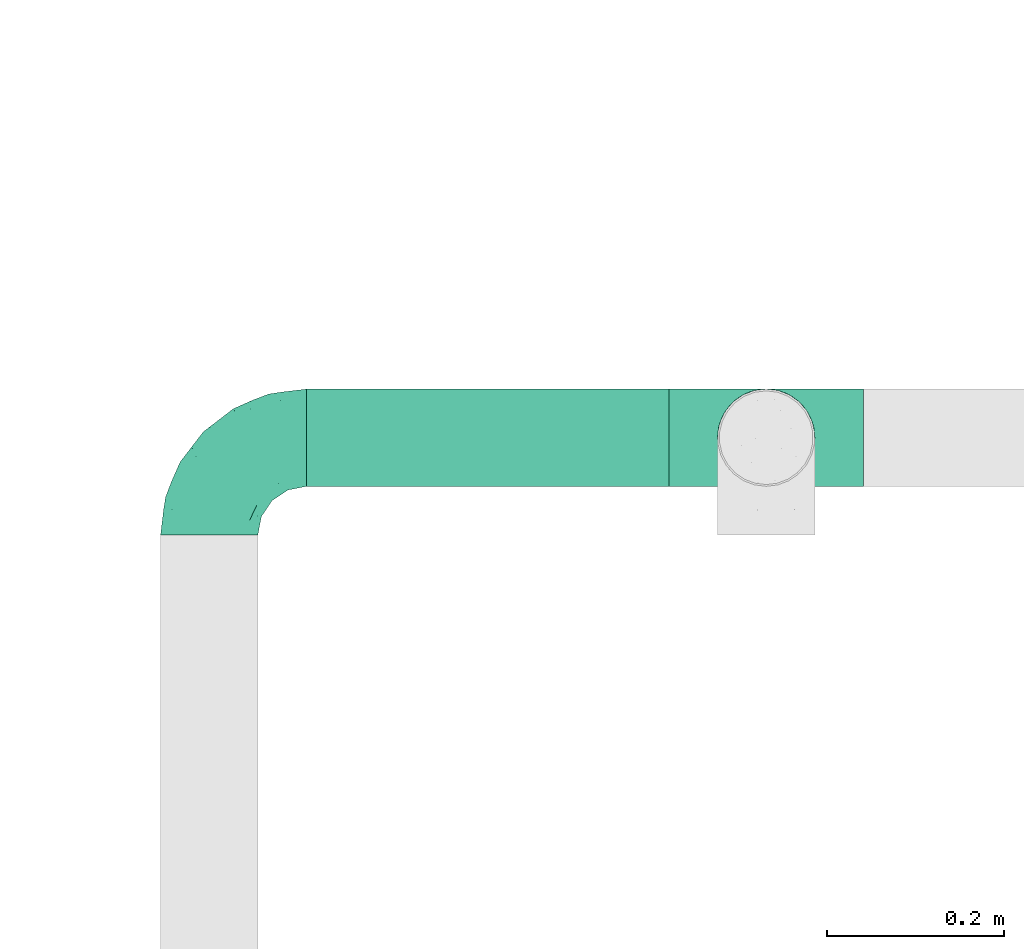
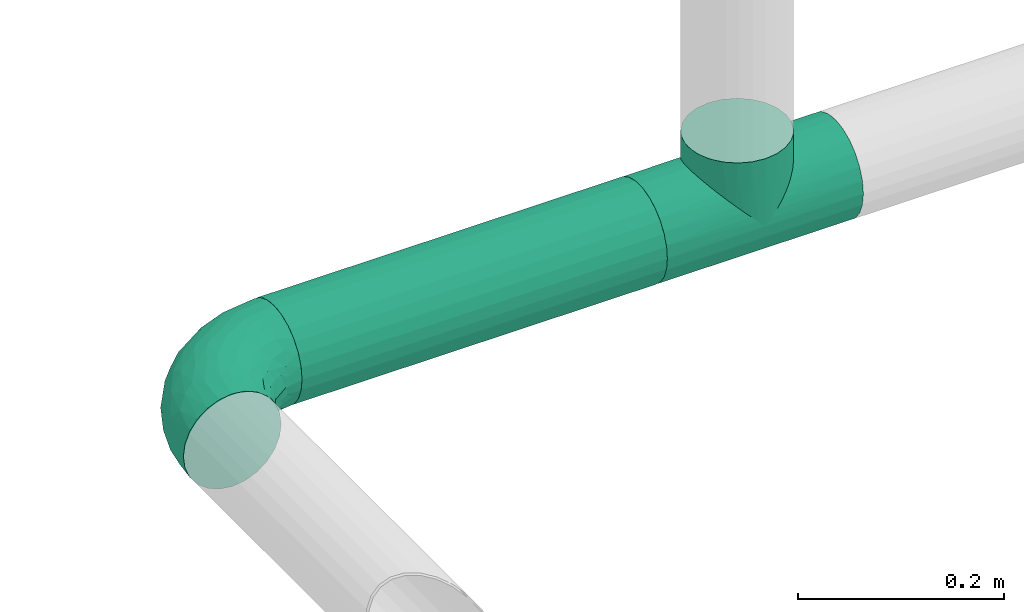
# One storey, part 73 of 103: 2 flow fittings, 1 flow segment.
"""IFC2X3 building model written with IfcOpenShell, lengths in millimetres."""

from ifc_helpers import new_model, entity, si_unit, converted_unit, derived_unit, direction, frame, origin_with_axes, origin_2d_with_axis, place, context, subcontext, project, spatial, hollow_circle, extrude, open_shell, surface_model, source, transform, mapped, material, layer, layer_set, layer_usage, type_object, element, save


model = new_model("IFC2X3")

# Units and contexts
model_context = context("Model", 3, precision=1e-05, world=origin_with_axes(), true_north=direction((0.0, 1.0)))
body_context = subcontext(model_context, "Body", "Model", "MODEL_VIEW")
ifc_project = project(units=[si_unit("AREAUNIT", "SQUARE_METRE"), si_unit("VOLUMEUNIT", "CUBIC_METRE", prefix="DECI"), si_unit("TIMEUNIT", "SECOND"), si_unit("THERMODYNAMICTEMPERATUREUNIT", "DEGREE_CELSIUS"), si_unit("PRESSUREUNIT", "PASCAL"), si_unit("MASSUNIT", "GRAM", prefix="KILO"), si_unit("LENGTHUNIT", "METRE", prefix="MILLI"), si_unit("POWERUNIT", "WATT"), si_unit("ELECTRICCURRENTUNIT", "AMPERE"), si_unit("ELECTRICVOLTAGEUNIT", "VOLT"), derived_unit("VOLUMETRICFLOWRATEUNIT", [(si_unit("VOLUMEUNIT", "CUBIC_METRE", prefix="DECI"), 1), (si_unit("TIMEUNIT", "SECOND"), -1)]), derived_unit("LINEARVELOCITYUNIT", [(si_unit("LENGTHUNIT", "METRE"), 1), (si_unit("TIMEUNIT", "SECOND"), -1)]), derived_unit("MASSDENSITYUNIT", [(si_unit("MASSUNIT", "GRAM", prefix="KILO"), 1), (si_unit("VOLUMEUNIT", "CUBIC_METRE"), -1)]), converted_unit("PLANEANGLEUNIT", "DEGREE", entity("IfcRatioMeasure", 0.01745), si_unit("PLANEANGLEUNIT", "RADIAN"), dimensions=[0, 0, 0, 0, 0, 0, 0])], contexts=[model_context])

# Site, building, storey
site_placement = place(None, origin_with_axes())
site = spatial("IfcSite", under=ifc_project, at=site_placement, CompositionType="ELEMENT")
building_placement = place(site_placement, origin_with_axes())
building = spatial("IfcBuilding", under=site, at=building_placement, Name="mc-building", CompositionType="ELEMENT")
storey_placement = place(building_placement, frame((0.0, 0.0, 5900.0), z_axis=(0.0, 0.0, 1.0), x_axis=(1.0, 0.0, 0.0)))
storey = spatial("IfcBuildingStorey", under=building, at=storey_placement, Name="3. Korrus", CompositionType="ELEMENT", Elevation=5900.0)

# Flow segment
ifc_material = material(Name="FZ1")
ifc_layer = layer(ifc_material, 0.0)
ifc_layer_set = layer_set([ifc_layer], Name="FZ1")
ifc_layer_usage = layer_usage(ifc_layer_set, "AXIS1", "POSITIVE", 0.0)
duct_segment_type = type_object("IfcDuctSegmentType", PredefinedType="RIGIDSEGMENT")
shared_shape_1 = source(origin_with_axes(), body_context, "Body", "SweptSolid", [
    extrude(hollow_circle(Radius=55.0, WallThickness=2.0, at=origin_2d_with_axis()), frame((0.0, 0.0, 0.0), z_axis=(1.0, 0.0, 0.0), x_axis=(0.0, 1.0, 0.0)), (0.0, 0.0, 1.0), 410.1),
])
flow_segment_placement = place(storey_placement, frame((18806.22014, 9477.62755, 2345.0), z_axis=(0.0, 0.0, 1.0), x_axis=(1.0, 0.0, 0.0)))
element("IfcFlowSegment", 1, at=flow_segment_placement, inside=storey, type_object=duct_segment_type, material=ifc_layer_usage, context=body_context, shape_type="MappedRepresentation", body=[
    mapped(shared_shape_1, transform((0.0, 0.0, 0.0), scale=1.0)),
])

# Flow fittings
duct_fitting_type_1 = type_object("IfcDuctFittingType", Name="BU", PredefinedType="BEND")
shared_shape_2 = source(origin_with_axes(), body_context, "Body", "SurfaceModel", [
    surface_model("IfcShellBasedSurfaceModel", [(-110.0, -38.89087, -38.89087), (-110.0, -55.0, 0.0), (-110.0, -27.5, -47.63139), (-110.0, -53.12592, -14.23505), (-110.0, -47.63139, -27.5), (-110.0, 47.63139, -27.5), (-110.0, 53.12592, 14.23505), (-110.0, 53.12592, -14.23505), (-110.0, -14.23505, -53.12592), (-110.0, 0.0, -55.0), (-110.0, 38.89087, -38.89087), (-110.0, 27.5, -47.63139), (-110.0, 14.23505, -53.12592), (-110.0, 55.0, 0.0), (-110.0, -53.12592, 14.23505), (-110.0, -47.63139, 27.5), (-110.0, -38.89087, 38.89087), (-110.0, 0.0, 55.0), (-110.0, -27.5, 47.63139), (-110.0, -14.23505, 53.12592), (-110.0, 38.89087, 38.89087), (-110.0, 47.63139, 27.5), (-110.0, 27.5, 47.63139), (-110.0, 14.23505, 53.12592), (0.0, -110.0, -55.0), (14.23505, -110.0, -53.12592), (-14.23505, -110.0, -53.12592), (-53.12592, -110.0, 14.23505), (-27.5, -110.0, -47.63139), (-47.63139, -110.0, -27.5), (-38.89087, -110.0, -38.89087), (55.0, -110.0, 0.0), (53.12592, -110.0, 14.23505), (38.89087, -110.0, -38.89087), (27.5, -110.0, -47.63139), (53.12592, -110.0, -14.23505), (47.63139, -110.0, -27.5), (-53.12592, -110.0, -14.23505), (-47.63139, -110.0, 27.5), (-38.89087, -110.0, 38.89087), (14.23505, -110.0, 53.12592), (-27.5, -110.0, 47.63139), (-14.23505, -110.0, 53.12592), (47.63139, -110.0, 27.5), (38.89087, -110.0, 38.89087), (27.5, -110.0, 47.63139), (0.0, -110.0, 55.0), (-55.0, -110.0, 0.0), (-60.44912, -32.56953, 51.94617), (-76.6405, -38.18013, 45.55988), (-64.21732, -48.68956, 43.63444), (-90.15553, -11.94394, 54.09138), (-76.00813, -5.38378, 55.0), (-70.18771, -18.55163, 54.03432), (-78.5998, -26.77405, 50.81338), (-93.27622, -45.77614, 33.48188), (-75.55424, -54.2118, 32.41257), (-96.12334, -22.13664, 50.81337), (-32.04182, -59.64019, 52.24446), (-18.36258, -70.48427, 54.04484), (-21.00813, -45.34362, 55.0), (-63.60674, -66.07878, 29.97482), (-74.66383, -63.08407, 19.92123), (-63.88653, -74.77858, 17.99134), (-93.11138, -56.59448, 10.50359), (-99.597, -52.72185, 18.52927), (-98.21577, -57.34403, 0.0), (-53.42855, -92.60092, 21.04759), (-88.54852, -54.8376, 21.04759), (-5.38378, -76.00813, 55.0), (-11.86161, -90.23965, 54.10313), (-56.64619, -93.12774, 10.22088), (-57.34403, -98.21577, 0.0), (-44.60838, -44.60838, 52.13415), (-45.34362, -21.00813, 55.0), (-92.68484, -35.46673, 43.63443), (-22.25266, -95.40765, 50.81337), (-27.23711, -77.39884, 50.81337), (-43.70931, -69.58671, 44.47149), (-35.97783, -90.61597, 43.63443), (-58.67786, -84.31125, 16.04456), (-57.2828, -79.3123, 24.9774), (-82.93277, -60.36161, 12.91784), (-49.88337, -54.51816, 47.224), (-74.57753, -66.83759, 9.55742), (-45.35812, -94.97281, 33.48188), (-59.18663, -88.95241, 0.0), (-51.517, -78.6292, 33.48188), (-65.14788, -80.03077, 0.0), (-56.45322, -62.06476, 39.63545), (-88.95241, -59.18663, 0.0), (-80.03077, -65.14788, 0.0), (-71.10913, -71.10913, 0.0), (-94.9309, -45.36788, -33.48188), (-93.11358, -56.60141, -10.46614), (-99.64997, -52.79499, -18.30015), (-79.99933, -46.56772, -37.92748), (-90.20425, -36.08686, -43.63443), (-45.34362, -21.00813, -55.0), (-72.75364, -19.68651, -53.60527), (-76.00813, -5.38378, -55.0), (-21.00813, -45.34362, -55.0), (-5.38378, -76.00813, -55.0), (-21.91957, -65.12078, -53.85897), (-35.41876, -92.89265, -43.63443), (-91.10309, -11.02766, -54.21832), (-45.77614, -93.27622, -33.48188), (-90.50474, -23.21022, -50.81337), (-70.92854, -33.31794, -49.51754), (-78.52933, -63.35627, -11.73997), (-24.91508, -84.05606, -50.81337), (-88.78941, -54.74452, -21.04759), (-63.49062, -67.59111, -28.46929), (-73.36422, -62.46673, -22.94182), (-69.59921, -57.34866, -33.48187), (-56.59448, -93.11138, -10.50359), (-54.10679, -75.85581, -32.31867), (-54.8376, -88.54852, -21.04759), (-57.75956, -31.09612, -52.80882), (-52.72185, -99.597, -18.52927), (-12.62913, -89.46304, -53.99097), (-34.46825, -66.46123, -50.04329), (-43.9837, -43.9837, -52.42279), (-65.78527, -72.58348, -17.68796), (-57.47001, -51.99467, -44.91465), (-70.34468, -43.65295, -44.21951), (-60.72547, -82.29174, -12.88567), (-42.34915, -74.24548, -43.63444), (-57.25194, -63.5016, -38.08211), (-80.95344, -53.56991, -29.32027), (-52.32891, -4.55257, -54.0482), (14.95561, -36.05775, -42.26543), (14.88266, -20.92917, -33.7947), (32.52942, -47.13398, -30.48571), (19.3559, -65.35825, -48.00507), (30.24048, -70.09027, -41.7461), (-28.49299, 30.5778, -16.4009), (-47.13398, 32.52942, -30.48571), (-70.35075, 46.44478, -19.5952), (-22.4954, -22.4954, -53.25347), (-4.55257, -52.32891, -54.0482), (-75.47368, 11.22546, -52.60718), (-81.32209, 51.5606, -9.98467), (-70.09027, 30.24048, -41.7461), (-80.81763, 41.84862, -32.14655), (-9.15831, 10.852, -27.8997), (-36.05774, 14.95561, -42.26543), (-65.35825, 19.3559, -48.00507), (3.94376, -43.9333, -50.53315), (11.22546, -75.47368, -52.60718), (-43.9333, 3.94376, -50.53315), (-13.39742, -13.39743, -48.13058), (50.20582, -74.51695, -9.9731), (41.8609, -47.82256, -9.92641), (49.37776, -67.29486, 0.0), (18.93131, -11.7156, -17.56239), (-1.23348, 12.25375, -12.18106), (-27.5, 32.89419, 0.0), (41.84862, -80.81763, -32.14655), (46.44478, -70.35075, -19.5952), (35.70604, -41.31408, -20.38235), (6.67262, 6.67262, 0.0), (32.89419, -27.5, 0.0), (-50.36265, 42.95545, -9.51562), (-67.29486, 49.37776, 0.0), (-5.47251, -5.47251, -39.92906), (-70.35075, 46.44478, 19.5952), (-74.51695, 50.20582, 9.9731), (-47.13398, 32.52942, 30.48571), (-41.31407, 35.70604, 20.38235), (-80.81763, 41.84862, 32.14655), (11.22546, -75.47368, 52.60718), (-4.55257, -52.32891, 54.0482), (-36.05774, 14.95561, 42.26543), (-65.35825, 19.3559, 48.00507), (-43.9333, 3.94376, 50.53315), (-70.09027, 30.24048, 41.7461), (-11.7156, 18.93131, 17.56239), (12.25375, -1.23348, 12.18106), (30.5778, -28.49299, 16.4009), (42.95545, -50.36265, 9.51562), (51.5606, -81.32209, 9.98467), (-52.32891, -4.55257, 54.0482), (-75.47368, 11.22546, 52.60718), (-13.39742, -13.39743, 48.13058), (-22.4954, -22.4954, 53.25347), (3.94376, -43.9333, 50.53315), (-20.92916, 14.88266, 33.79469), (10.852, -9.15831, 27.8997), (-47.82256, 41.8609, 9.92641), (32.52942, -47.13398, 30.48571), (46.44478, -70.35075, 19.5952), (41.84862, -80.81763, 32.14655), (14.95561, -36.05775, 42.26543), (19.3559, -65.35825, 48.00507), (30.24048, -70.09027, 41.7461), (-5.47251, -5.47251, 39.92906)], [open_shell([[[0, 1, 2]], [[3, 1, 4]], [[5, 6, 7]], [[8, 1, 9]], [[2, 1, 8]], [[4, 1, 0]], [[10, 9, 6]], [[9, 10, 11]], [[11, 12, 9]], [[6, 5, 10]], [[7, 6, 13]], [[14, 15, 9]], [[9, 15, 16]], [[17, 16, 18]], [[9, 16, 17]], [[19, 17, 18]], [[9, 20, 21]], [[6, 9, 21]], [[9, 22, 20]], [[23, 22, 9]], [[17, 23, 9]], [[9, 1, 14]], [[24, 25, 26]], [[26, 27, 28]], [[29, 30, 27]], [[28, 27, 30]], [[26, 31, 32]], [[33, 31, 34]], [[25, 34, 31]], [[35, 31, 36]], [[33, 36, 31]], [[31, 26, 25]], [[29, 27, 37]], [[38, 27, 26]], [[39, 38, 26]], [[40, 41, 26]], [[41, 39, 26]], [[40, 42, 41]], [[43, 44, 26]], [[43, 26, 32]], [[44, 45, 26]], [[26, 45, 40]], [[40, 46, 42]], [[47, 37, 27]], [[48, 49, 50]], [[51, 52, 17]], [[48, 53, 54]], [[49, 55, 56]], [[16, 15, 55]], [[18, 57, 19]], [[58, 59, 60]], [[61, 62, 63]], [[64, 65, 14]], [[53, 51, 54]], [[66, 64, 14]], [[27, 38, 67]], [[65, 68, 55]], [[68, 65, 64]], [[69, 59, 70]], [[71, 72, 27]], [[73, 60, 74]], [[55, 49, 75]], [[42, 70, 76]], [[51, 57, 54]], [[77, 78, 79]], [[42, 76, 41]], [[46, 70, 42]], [[55, 68, 56]], [[75, 18, 16]], [[77, 79, 76]], [[80, 67, 81]], [[68, 82, 62]], [[83, 78, 58]], [[82, 84, 62]], [[39, 79, 85]], [[71, 67, 80]], [[72, 71, 86]], [[67, 85, 87]], [[88, 80, 63]], [[39, 41, 79]], [[87, 79, 78]], [[55, 75, 16]], [[50, 89, 83]], [[38, 39, 85]], [[56, 68, 62]], [[61, 87, 89]], [[48, 50, 83]], [[18, 75, 57]], [[54, 75, 49]], [[38, 85, 67]], [[85, 79, 87]], [[56, 62, 61]], [[50, 56, 89]], [[87, 61, 81]], [[90, 64, 66]], [[14, 1, 66]], [[91, 92, 84]], [[82, 90, 91]], [[90, 82, 64]], [[62, 84, 63]], [[84, 82, 91]], [[64, 82, 68]], [[65, 15, 14]], [[15, 65, 55]], [[72, 47, 27]], [[86, 71, 80]], [[67, 71, 27]], [[88, 63, 92]], [[63, 80, 81]], [[63, 81, 61]], [[87, 81, 67]], [[41, 76, 79]], [[70, 59, 77]], [[76, 70, 77]], [[69, 70, 46]], [[77, 59, 58]], [[59, 69, 60]], [[77, 58, 78]], [[73, 58, 60]], [[19, 57, 51]], [[54, 57, 75]], [[19, 51, 17]], [[53, 52, 51]], [[53, 74, 52]], [[73, 74, 48]], [[53, 48, 74]], [[83, 73, 48]], [[73, 83, 58]], [[78, 83, 89]], [[78, 89, 87]], [[61, 89, 56]], [[54, 49, 48]], [[50, 49, 56]], [[88, 86, 80]], [[63, 84, 92]], [[93, 4, 0]], [[66, 94, 90]], [[95, 94, 3]], [[96, 93, 97]], [[98, 99, 100]], [[0, 2, 97]], [[101, 102, 103]], [[104, 28, 30]], [[9, 105, 8]], [[30, 106, 104]], [[107, 105, 99]], [[97, 107, 108]], [[94, 109, 90]], [[2, 8, 107]], [[94, 66, 3]], [[110, 26, 28]], [[94, 111, 109]], [[112, 113, 114]], [[72, 115, 37]], [[116, 106, 117]], [[98, 118, 99]], [[119, 115, 117]], [[115, 119, 37]], [[110, 120, 26]], [[103, 110, 121]], [[117, 106, 119]], [[120, 110, 103]], [[98, 101, 122]], [[117, 123, 116]], [[108, 124, 125]], [[126, 117, 115]], [[30, 29, 106]], [[120, 102, 24]], [[110, 104, 127]], [[97, 125, 96]], [[118, 122, 124]], [[124, 127, 128]], [[93, 0, 97]], [[86, 126, 115]], [[127, 106, 116]], [[129, 113, 111]], [[4, 93, 95]], [[114, 129, 96]], [[28, 104, 110]], [[127, 104, 106]], [[2, 107, 97]], [[108, 107, 99]], [[118, 108, 99]], [[100, 99, 105]], [[128, 112, 114]], [[127, 124, 121]], [[66, 1, 3]], [[91, 90, 109]], [[95, 111, 94]], [[109, 123, 92]], [[114, 113, 129]], [[111, 95, 93]], [[95, 3, 4]], [[86, 115, 72]], [[37, 47, 72]], [[88, 92, 123]], [[123, 117, 126]], [[126, 88, 123]], [[88, 126, 86]], [[119, 29, 37]], [[29, 119, 106]], [[111, 93, 129]], [[124, 114, 125]], [[100, 105, 9]], [[8, 105, 107]], [[108, 118, 124]], [[122, 118, 98]], [[96, 129, 93]], [[109, 111, 113]], [[113, 123, 109]], [[116, 123, 112]], [[113, 112, 123]], [[116, 112, 128]], [[116, 128, 127]], [[124, 128, 114]], [[103, 122, 101]], [[127, 121, 110]], [[121, 122, 103]], [[122, 121, 124]], [[26, 120, 24]], [[102, 120, 103]], [[108, 125, 97]], [[109, 92, 91]], [[96, 125, 114]], [[100, 130, 98]], [[131, 132, 133]], [[134, 135, 34]], [[136, 137, 138]], [[101, 139, 140]], [[9, 141, 100]], [[138, 7, 142]], [[137, 143, 144]], [[142, 7, 13]], [[145, 146, 137]], [[146, 147, 143]], [[5, 138, 144]], [[7, 138, 5]], [[5, 144, 10]], [[140, 148, 149]], [[143, 11, 10]], [[147, 12, 11]], [[100, 141, 130]], [[98, 139, 101]], [[148, 134, 149]], [[139, 150, 151]], [[152, 153, 154]], [[150, 139, 130]], [[25, 24, 149]], [[141, 12, 147]], [[132, 145, 155]], [[156, 136, 157]], [[158, 33, 135]], [[148, 139, 151]], [[36, 33, 158]], [[34, 135, 33]], [[159, 160, 153]], [[160, 159, 133]], [[137, 146, 143]], [[152, 154, 31]], [[137, 136, 145]], [[161, 162, 155]], [[133, 159, 158]], [[134, 148, 131]], [[163, 164, 157]], [[163, 142, 164]], [[102, 101, 140]], [[162, 154, 153]], [[159, 35, 36]], [[155, 156, 161]], [[131, 165, 132]], [[155, 145, 156]], [[98, 130, 139]], [[150, 130, 141]], [[147, 150, 141]], [[9, 12, 141]], [[149, 24, 102]], [[148, 140, 139]], [[140, 149, 102]], [[34, 25, 134]], [[146, 151, 150]], [[143, 147, 11]], [[147, 146, 150]], [[145, 165, 146]], [[25, 149, 134]], [[135, 134, 131]], [[135, 131, 133]], [[151, 165, 131]], [[148, 151, 131]], [[165, 151, 146]], [[160, 133, 132]], [[132, 165, 145]], [[36, 158, 159]], [[133, 158, 135]], [[10, 144, 143]], [[137, 144, 138]], [[162, 153, 155]], [[159, 153, 152]], [[160, 155, 153]], [[155, 160, 132]], [[152, 35, 159]], [[35, 152, 31]], [[136, 138, 163]], [[164, 142, 13]], [[142, 163, 138]], [[136, 163, 157]], [[161, 156, 157]], [[136, 156, 145]], [[166, 6, 21]], [[167, 164, 13]], [[166, 168, 169]], [[170, 168, 166]], [[69, 171, 172]], [[173, 174, 175]], [[174, 176, 22]], [[161, 157, 177]], [[170, 20, 176]], [[21, 20, 170]], [[178, 179, 162]], [[180, 181, 154]], [[182, 175, 183]], [[183, 23, 17]], [[184, 185, 186]], [[74, 185, 182]], [[52, 74, 182]], [[187, 188, 177]], [[166, 169, 189]], [[190, 179, 188]], [[22, 176, 20]], [[180, 154, 162]], [[32, 191, 43]], [[192, 44, 43]], [[43, 191, 192]], [[32, 31, 181]], [[193, 194, 195]], [[194, 40, 45]], [[190, 193, 195]], [[45, 44, 195]], [[69, 46, 171]], [[74, 60, 185]], [[157, 164, 189]], [[167, 189, 164]], [[172, 60, 69]], [[185, 172, 186]], [[173, 187, 168]], [[191, 32, 181]], [[190, 195, 192]], [[179, 190, 191]], [[175, 174, 183]], [[171, 40, 194]], [[188, 193, 190]], [[175, 185, 184]], [[177, 178, 161]], [[173, 196, 187]], [[177, 188, 178]], [[60, 172, 185]], [[186, 172, 171]], [[194, 186, 171]], [[46, 40, 171]], [[183, 17, 52]], [[175, 182, 185]], [[182, 183, 52]], [[22, 23, 174]], [[193, 184, 186]], [[195, 194, 45]], [[194, 193, 186]], [[188, 196, 193]], [[23, 183, 174]], [[176, 174, 173]], [[176, 173, 168]], [[184, 196, 173]], [[175, 184, 173]], [[196, 184, 193]], [[169, 168, 187]], [[187, 196, 188]], [[21, 170, 166]], [[168, 170, 176]], [[44, 192, 195]], [[190, 192, 191]], [[157, 189, 177]], [[166, 189, 167]], [[169, 177, 189]], [[177, 169, 187]], [[167, 6, 166]], [[6, 167, 13]], [[179, 191, 180]], [[154, 181, 31]], [[181, 180, 191]], [[179, 180, 162]], [[161, 178, 162]], [[179, 178, 188]]])]),
])
flow_fitting_1_placement = place(storey_placement, frame((18696.22014, 9477.62755, 2345.0), z_axis=(0.0, 0.0, 1.0), x_axis=(0.0, 1.0, 0.0)))
element("IfcFlowFitting", 2, at=flow_fitting_1_placement, inside=storey, type_object=duct_fitting_type_1, Name="BU", context=body_context, shape_type="MappedRepresentation", body=[
    mapped(shared_shape_2, transform((0.0, 0.0, 0.0), scale=1.0)),
])
duct_fitting_type_2 = type_object("IfcDuctFittingType", PredefinedType="JUNCTION")
shared_shape_3 = source(origin_with_axes(), body_context, "Body", "SurfaceModel", [
    surface_model("IfcShellBasedSurfaceModel", [(-110.0, -38.89087, -38.89087), (-110.0, -55.0, 0.0), (-110.0, -27.5, -47.63139), (-110.0, -53.12592, -14.23505), (-110.0, -47.63139, -27.5), (-110.0, 47.63139, -27.5), (-110.0, 53.12592, 14.23505), (-110.0, 53.12592, -14.23505), (-110.0, 55.0, 0.0), (110.0, 38.89087, -38.89087), (110.0, 55.0, 0.0), (110.0, 27.5, -47.63139), (110.0, -38.89087, -38.89087), (110.0, -53.12592, 14.23505), (110.0, -47.63139, -27.5), (110.0, -55.0, 0.0), (110.0, -53.12592, -14.23505), (110.0, 53.12592, -14.23505), (110.0, 47.63139, -27.5), (-110.0, 38.89087, -38.89087), (-110.0, -14.23505, -53.12592), (-110.0, 0.0, -55.0), (-110.0, 27.5, -47.63139), (-110.0, 14.23505, -53.12592), (-110.0, -53.12592, 14.23505), (-110.0, -47.63139, 27.5), (-110.0, -38.89087, 38.89087), (-110.0, 14.23505, 53.12592), (-110.0, 27.5, 47.63139), (-55.0, 80.0, 0.0), (0.0, 80.0, -55.0), (-14.23505, 80.0, -53.12592), (-27.5, 80.0, -47.63139), (-38.89087, 80.0, -38.89087), (-47.63139, 80.0, -27.5), (38.89087, 80.0, -38.89087), (53.12592, 80.0, 14.23505), (27.5, 80.0, -47.63139), (14.23505, 80.0, -53.12592), (47.63139, 80.0, -27.5), (53.12592, 80.0, -14.23505), (55.0, 80.0, 0.0), (-53.12592, 80.0, -14.23505), (-53.12592, 80.0, 14.23505), (-47.63139, 80.0, 27.5), (-38.89087, 80.0, 38.89087), (0.0, 80.0, 55.0), (-27.5, 80.0, 47.63139), (-14.23505, 80.0, 53.12592), (47.63139, 80.0, 27.5), (38.89087, 80.0, 38.89087), (27.5, 80.0, 47.63139), (14.23505, 80.0, 53.12592), (-7.4066, 7.4066, 54.49901), (0.0, 0.0, 55.0), (-21.93978, 21.93978, 50.43457), (-14.74521, 14.74521, 52.98659), (-35.50357, 35.50357, 42.00591), (-28.89905, 28.89905, 46.79578), (-46.92319, 46.92319, 28.69171), (-41.58668, 41.58668, 35.99373), (-54.01174, 54.01174, 10.37938), (-54.06296, 80.0, 7.11752), (-55.0, 55.0, 0.0), (-51.19777, 51.19777, 20.0945), (-50.37866, 80.0, 20.86752), (-51.19777, 51.19777, -20.0945), (-54.01174, 54.01174, -10.37938), (-50.37866, 80.0, -20.86752), (-41.58668, 41.58668, -35.99373), (-46.92319, 46.92319, -28.69171), (-54.06296, 80.0, -7.11752), (-35.50357, 35.50357, -42.00591), (-14.74521, 14.74521, -52.98659), (-21.93978, 21.93978, -50.43457), (0.0, 0.0, -55.0), (-7.4066, 7.4066, -54.49901), (-28.89905, 28.89905, -46.79578), (7.4066, 7.4066, -54.49901), (21.93978, 21.93978, -50.43457), (14.74521, 14.74521, -52.98659), (35.50357, 35.50357, -42.00591), (28.89905, 28.89905, -46.79578), (46.92319, 46.92319, -28.69171), (41.58668, 41.58668, -35.99373), (54.01174, 54.01174, -10.37938), (54.06296, 80.0, -7.11752), (55.0, 55.0, 0.0), (51.19777, 51.19777, -20.0945), (50.37866, 80.0, -20.86752), (51.19777, 51.19777, 20.0945), (54.01174, 54.01174, 10.37938), (50.37866, 80.0, 20.86752), (41.58668, 41.58668, 35.99373), (46.92319, 46.92319, 28.69171), (54.06296, 80.0, 7.11752), (35.50357, 35.50357, 42.00591), (14.74521, 14.74521, 52.98659), (21.93978, 21.93978, 50.43457), (7.4066, 7.4066, 54.49901), (28.89905, 28.89905, 46.79578), (-110.0, -27.5, 47.63139), (-110.0, 0.0, 55.0), (-110.0, -14.23505, 53.12592), (-110.0, 47.63139, 27.5), (-110.0, 38.89087, 38.89087), (110.0, 0.0, -55.0), (110.0, 14.23505, -53.12592), (110.0, -14.23505, -53.12592), (110.0, -27.5, -47.63139), (110.0, 53.12592, 14.23505), (110.0, -47.63139, 27.5), (110.0, -38.89087, 38.89087), (110.0, 14.23505, 53.12592), (110.0, -27.5, 47.63139), (110.0, -14.23505, 53.12592), (110.0, 47.63139, 27.5), (110.0, 38.89087, 38.89087), (110.0, 27.5, 47.63139), (110.0, 0.0, 55.0)], [open_shell([[[0, 1, 2]], [[3, 1, 4]], [[5, 6, 7]], [[8, 7, 6]], [[9, 10, 11]], [[12, 13, 14]], [[15, 16, 13]], [[17, 10, 18]], [[19, 6, 5]], [[2, 1, 20]], [[19, 21, 6]], [[21, 19, 22]], [[22, 23, 21]], [[24, 25, 21]], [[21, 25, 26]], [[27, 28, 21]], [[29, 30, 31]], [[32, 29, 31]], [[29, 33, 34]], [[29, 32, 33]], [[35, 30, 36]], [[30, 35, 37]], [[37, 38, 30]], [[35, 36, 39]], [[39, 36, 40]], [[41, 40, 36]], [[42, 29, 34]], [[43, 44, 30]], [[30, 44, 45]], [[46, 30, 47]], [[30, 45, 47]], [[46, 47, 48]], [[49, 36, 30]], [[50, 49, 30]], [[51, 50, 30]], [[52, 51, 30]], [[52, 30, 46]], [[29, 43, 30]], [[46, 53, 54]], [[48, 55, 56]], [[48, 56, 53]], [[48, 53, 46]], [[57, 58, 47]], [[55, 48, 47]], [[45, 57, 47]], [[55, 47, 58]], [[44, 59, 60]], [[61, 62, 63]], [[43, 61, 64]], [[65, 43, 64]], [[44, 64, 59]], [[44, 60, 45]], [[43, 62, 61]], [[64, 44, 65]], [[29, 63, 62]], [[57, 45, 60]], [[42, 66, 67]], [[68, 34, 66]], [[34, 69, 70]], [[71, 42, 67]], [[34, 70, 66]], [[63, 71, 67]], [[29, 71, 63]], [[68, 66, 42]], [[34, 33, 69]], [[33, 72, 69]], [[31, 73, 74]], [[30, 75, 76]], [[31, 76, 73]], [[32, 77, 72]], [[77, 32, 74]], [[32, 31, 74]], [[31, 30, 76]], [[33, 32, 72]], [[30, 78, 75]], [[38, 79, 80]], [[38, 80, 78]], [[38, 78, 30]], [[81, 82, 37]], [[79, 38, 37]], [[35, 81, 37]], [[79, 37, 82]], [[39, 83, 84]], [[85, 86, 87]], [[40, 85, 88]], [[89, 40, 88]], [[39, 88, 83]], [[39, 84, 35]], [[40, 86, 85]], [[88, 39, 89]], [[41, 87, 86]], [[81, 35, 84]], [[36, 90, 91]], [[92, 49, 90]], [[49, 93, 94]], [[95, 36, 91]], [[49, 94, 90]], [[87, 95, 91]], [[95, 87, 41]], [[36, 92, 90]], [[49, 50, 93]], [[50, 96, 93]], [[52, 97, 98]], [[46, 54, 99]], [[52, 99, 97]], [[51, 100, 96]], [[100, 51, 98]], [[51, 52, 98]], [[52, 46, 99]], [[50, 51, 96]], [[1, 21, 20]], [[1, 0, 4]], [[101, 102, 26]], [[102, 21, 26]], [[102, 101, 103]], [[104, 6, 21]], [[105, 104, 21]], [[105, 21, 28]], [[21, 102, 27]], [[1, 24, 21]], [[106, 107, 108]], [[108, 13, 109]], [[109, 13, 12]], [[108, 10, 110]], [[107, 11, 10]], [[9, 18, 10]], [[10, 108, 107]], [[16, 14, 13]], [[108, 111, 13]], [[108, 112, 111]], [[108, 113, 114]], [[114, 112, 108]], [[113, 115, 114]], [[108, 110, 116]], [[108, 116, 117]], [[108, 117, 118]], [[113, 108, 118]], [[113, 119, 115]], [[115, 119, 54]], [[114, 115, 101]], [[103, 54, 102]], [[115, 54, 103]], [[103, 101, 115]], [[101, 26, 114]], [[111, 112, 25]], [[13, 111, 24]], [[15, 13, 1]], [[25, 112, 26]], [[24, 111, 25]], [[24, 1, 13]], [[114, 26, 112]], [[16, 15, 3]], [[14, 16, 4]], [[3, 15, 1]], [[4, 16, 3]], [[4, 0, 14]], [[0, 12, 14]], [[109, 12, 2]], [[108, 109, 20]], [[106, 108, 75]], [[20, 109, 2]], [[20, 21, 75]], [[20, 75, 108]], [[0, 2, 12]], [[21, 76, 75]], [[23, 74, 73]], [[23, 73, 76]], [[23, 76, 21]], [[72, 77, 22]], [[74, 23, 22]], [[19, 72, 22]], [[74, 22, 77]], [[5, 70, 69]], [[7, 67, 66]], [[5, 66, 70]], [[5, 69, 19]], [[7, 8, 67]], [[66, 5, 7]], [[63, 67, 8]], [[72, 19, 69]], [[107, 106, 78]], [[79, 11, 107]], [[9, 11, 81]], [[11, 82, 81]], [[106, 75, 78]], [[107, 80, 79]], [[11, 79, 82]], [[80, 107, 78]], [[18, 9, 84]], [[17, 18, 88]], [[10, 17, 85]], [[18, 84, 83]], [[17, 88, 85]], [[10, 85, 87]], [[88, 18, 83]], [[81, 84, 9]], [[110, 10, 91]], [[116, 110, 90]], [[117, 116, 93]], [[10, 87, 91]], [[116, 90, 94]], [[116, 94, 93]], [[90, 110, 91]], [[93, 96, 117]], [[118, 96, 100]], [[117, 96, 118]], [[113, 118, 98]], [[119, 113, 99]], [[118, 100, 98]], [[113, 97, 99]], [[119, 99, 54]], [[97, 113, 98]], [[6, 64, 61]], [[104, 60, 59]], [[104, 59, 64]], [[8, 61, 63]], [[61, 8, 6]], [[6, 104, 64]], [[104, 105, 60]], [[105, 57, 60]], [[27, 56, 55]], [[102, 54, 53]], [[27, 53, 56]], [[28, 58, 57]], [[58, 28, 55]], [[28, 27, 55]], [[27, 102, 53]], [[105, 28, 57]]])]),
])
flow_fitting_2_placement = place(storey_placement, frame((19326.27346, 9477.62755, 2345.0), z_axis=(0.0, 1.0, 0.0), x_axis=(-1.0, 0.0, 0.0)))
element("IfcFlowFitting", 3, at=flow_fitting_2_placement, inside=storey, type_object=duct_fitting_type_2, context=body_context, shape_type="MappedRepresentation", body=[
    mapped(shared_shape_3, transform((0.0, 0.0, 0.0), scale=1.0)),
])

save(model, "model.ifc")
